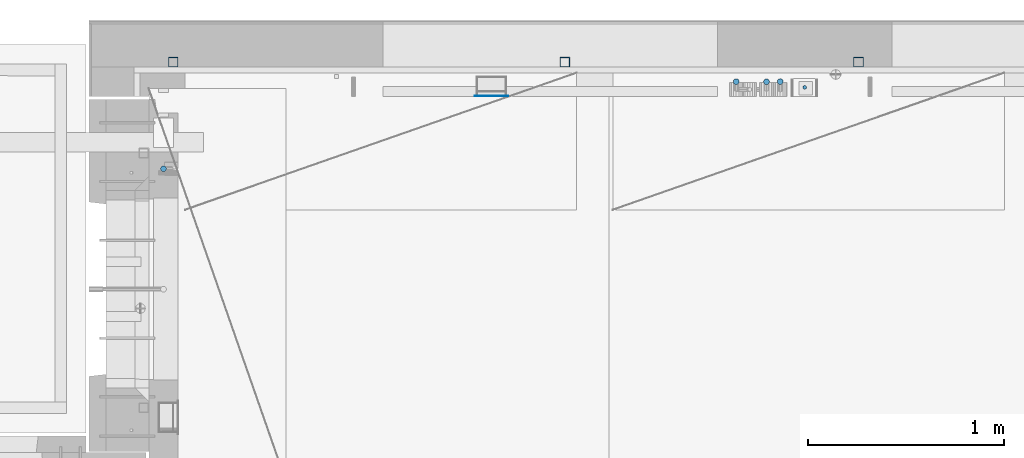
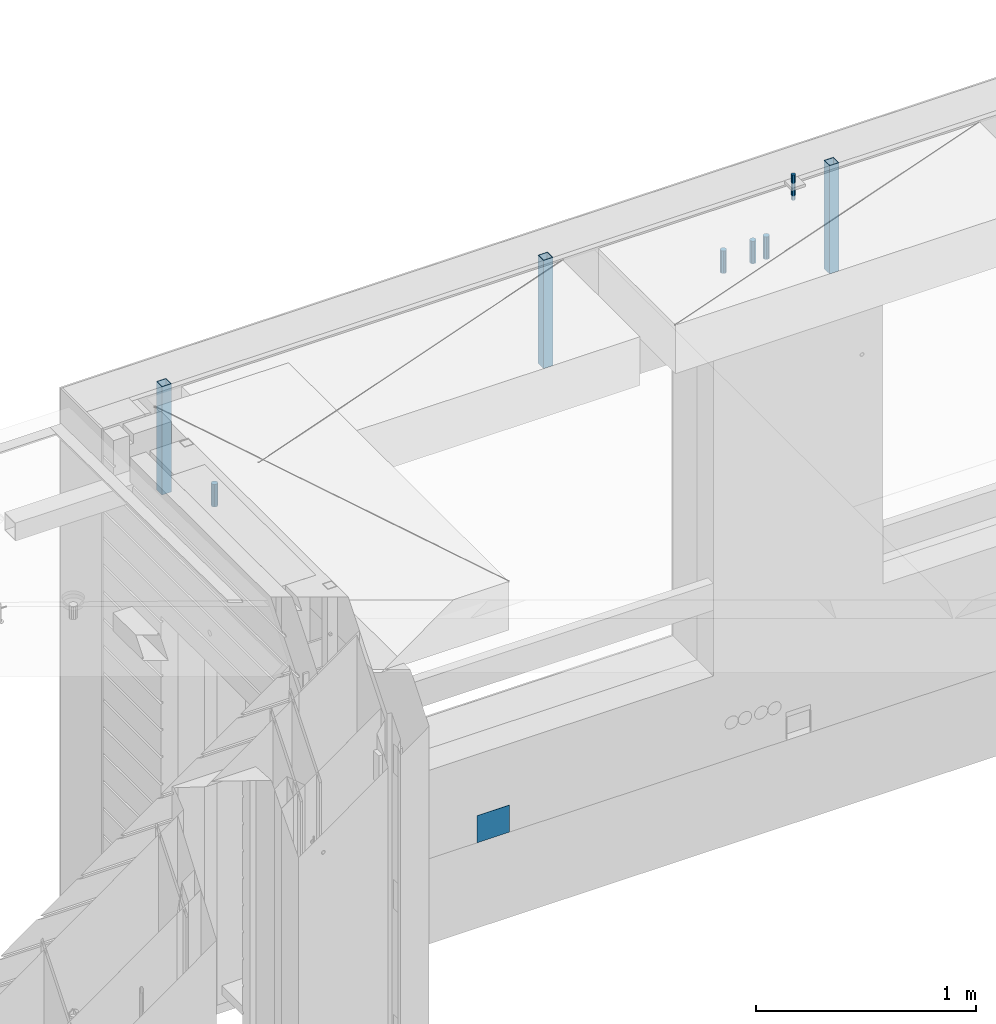
# One storey, part 29 of 350: 9 columns, 7 elements without a shape of their own.
"""IFC2X3 building model written with IfcOpenShell, lengths in millimetres."""

from ifc_helpers import new_model, si_unit, frame, origin_with_axes, place, context, subcontext, project, spatial, faceted_brep, material, type_object, element, aggregate, save


model = new_model("IFC2X3")

# Units and contexts
model_context = context("Model", 3, precision=1e-05, world=origin_with_axes())
body_context = subcontext(model_context, "Body", "Model", "MODEL_VIEW")
ifc_project = project(units=[si_unit("LENGTHUNIT", "METRE", prefix="MILLI"), si_unit("AREAUNIT", "SQUARE_METRE"), si_unit("VOLUMEUNIT", "CUBIC_METRE"), si_unit("MASSUNIT", "GRAM", prefix="KILO"), si_unit("TIMEUNIT", "SECOND"), si_unit("PLANEANGLEUNIT", "RADIAN"), si_unit("SOLIDANGLEUNIT", "STERADIAN"), si_unit("THERMODYNAMICTEMPERATUREUNIT", "DEGREE_CELSIUS"), si_unit("LUMINOUSINTENSITYUNIT", "LUMEN")], contexts=[model_context])

# Site, building, storey
site_placement = place(None, origin_with_axes())
site = spatial("IfcSite", under=ifc_project, at=site_placement, CompositionType="ELEMENT")
building_placement = place(site_placement, origin_with_axes())
building = spatial("IfcBuilding", under=site, at=building_placement, CompositionType="ELEMENT")
storey_placement = place(building_placement, origin_with_axes())
storey = spatial("IfcBuildingStorey", under=building, at=storey_placement, Name="2", CompositionType="ELEMENT", Elevation=0.0)

# Assembly, columns
assembly_1_placement = place(storey_placement, origin_with_axes())
assembly_1 = element("IfcElementAssembly", 1, at=assembly_1_placement, inside=storey, AssemblyPlace="NOTDEFINED", PredefinedType="REINFORCEMENT_UNIT")
ifc_material_1 = material()
column_type_1 = type_object("IfcColumnType", Name="D30", PredefinedType="NOTDEFINED")
column_1_placement = place(assembly_1_placement, frame((13990.0000000048, 22694.9999977209, 87407.5), z_axis=(0.0, 1.0, 0.0), x_axis=(0.0, 0.0, 1.0)))
column_1 = element("IfcColumn", 2, at=column_1_placement, type_object=column_type_1, material=ifc_material_1, ObjectType="D30", context=body_context, shape_type="Brep", body=[
    faceted_brep([(0.0, -15.0, 0.0), (0.0, -12.9903810567666, -7.5), (125.0, -12.9903810567666, -7.5), (125.0, -15.0, 0.0), (0.0, -7.5, -12.9903810567666), (125.0, -7.5, -12.9903810567666), (0.0, 0.0, -15.0), (125.0, 0.0, -15.0), (0.0, 7.5, -12.9903810567666), (125.0, 7.5, -12.9903810567666), (0.0, 12.9903810567666, -7.5), (125.0, 12.9903810567666, -7.5), (0.0, 15.0, 0.0), (125.0, 15.0, 0.0), (0.0, 12.9903810567666, 7.5), (125.0, 12.9903810567666, 7.5), (0.0, 7.5, 12.9903810567666), (125.0, 7.5, 12.9903810567666), (0.0, 0.0, 15.0), (125.0, 0.0, 15.0), (0.0, -7.5, 12.9903810567666), (125.0, -7.5, 12.9903810567666), (0.0, -12.9903810567666, 7.5), (125.0, -12.9903810567666, 7.5)], [[[0, 1, 2, 3]], [[1, 4, 5, 2]], [[4, 6, 7, 5]], [[6, 8, 9, 7]], [[8, 10, 11, 9]], [[10, 12, 13, 11]], [[12, 14, 15, 13]], [[14, 16, 17, 15]], [[16, 18, 19, 17]], [[18, 20, 21, 19]], [[20, 22, 23, 21]], [[22, 0, 3, 23]], [[5, 7, 9, 11, 13, 15, 17, 19, 21, 23, 3, 2]], [[22, 20, 18, 16, 14, 12, 10, 8, 6, 4, 1, 0]]]),
])
column_2_placement = place(assembly_1_placement, frame((14145.0000000048, 22694.9999977209, 87407.5), z_axis=(0.0, 1.0, 0.0), x_axis=(0.0, 0.0, 1.0)))
column_2 = element("IfcColumn", 3, at=column_2_placement, type_object=column_type_1, material=ifc_material_1, ObjectType="D30", context=body_context, shape_type="Brep", body=[
    faceted_brep([(0.0, -15.0, 0.0), (0.0, -12.9903810567666, -7.5), (125.0, -12.9903810567666, -7.5), (125.0, -15.0, 0.0), (0.0, -7.5, -12.9903810567666), (125.0, -7.5, -12.9903810567666), (0.0, 0.0, -15.0), (125.0, 0.0, -15.0), (0.0, 7.5, -12.9903810567666), (125.0, 7.5, -12.9903810567666), (0.0, 12.9903810567666, -7.5), (125.0, 12.9903810567666, -7.5), (0.0, 15.0, 0.0), (125.0, 15.0, 0.0), (0.0, 12.9903810567666, 7.5), (125.0, 12.9903810567666, 7.5), (0.0, 7.5, 12.9903810567666), (125.0, 7.5, 12.9903810567666), (0.0, 0.0, 15.0), (125.0, 0.0, 15.0), (0.0, -7.5, 12.9903810567666), (125.0, -7.5, 12.9903810567666), (0.0, -12.9903810567666, 7.5), (125.0, -12.9903810567666, 7.5)], [[[0, 1, 2, 3]], [[1, 4, 5, 2]], [[4, 6, 7, 5]], [[6, 8, 9, 7]], [[8, 10, 11, 9]], [[10, 12, 13, 11]], [[12, 14, 15, 13]], [[14, 16, 17, 15]], [[16, 18, 19, 17]], [[18, 20, 21, 19]], [[20, 22, 23, 21]], [[22, 0, 3, 23]], [[5, 7, 9, 11, 13, 15, 17, 19, 21, 23, 3, 2]], [[22, 20, 18, 16, 14, 12, 10, 8, 6, 4, 1, 0]]]),
])
column_3_placement = place(assembly_1_placement, frame((14215.0000000048, 22694.9999977209, 87407.5), z_axis=(0.0, 1.0, 0.0), x_axis=(0.0, 0.0, 1.0)))
column_3 = element("IfcColumn", 4, at=column_3_placement, type_object=column_type_1, material=ifc_material_1, ObjectType="D30", context=body_context, shape_type="Brep", body=[
    faceted_brep([(0.0, -15.0, 0.0), (0.0, -12.9903810567666, -7.5), (125.0, -12.9903810567666, -7.5), (125.0, -15.0, 0.0), (0.0, -7.5, -12.9903810567666), (125.0, -7.5, -12.9903810567666), (0.0, 0.0, -15.0), (125.0, 0.0, -15.0), (0.0, 7.5, -12.9903810567666), (125.0, 7.5, -12.9903810567666), (0.0, 12.9903810567666, -7.5), (125.0, 12.9903810567666, -7.5), (0.0, 15.0, 0.0), (125.0, 15.0, 0.0), (0.0, 12.9903810567666, 7.5), (125.0, 12.9903810567666, 7.5), (0.0, 7.5, 12.9903810567666), (125.0, 7.5, 12.9903810567666), (0.0, 0.0, 15.0), (125.0, 0.0, 15.0), (0.0, -7.5, 12.9903810567666), (125.0, -7.5, 12.9903810567666), (0.0, -12.9903810567666, 7.5), (125.0, -12.9903810567666, 7.5)], [[[0, 1, 2, 3]], [[1, 4, 5, 2]], [[4, 6, 7, 5]], [[6, 8, 9, 7]], [[8, 10, 11, 9]], [[10, 12, 13, 11]], [[12, 14, 15, 13]], [[14, 16, 17, 15]], [[16, 18, 19, 17]], [[18, 20, 21, 19]], [[20, 22, 23, 21]], [[22, 0, 3, 23]], [[5, 7, 9, 11, 13, 15, 17, 19, 21, 23, 3, 2]], [[22, 20, 18, 16, 14, 12, 10, 8, 6, 4, 1, 0]]]),
])

# Assembly, column
assembly_2_placement = place(storey_placement, origin_with_axes())
assembly_2 = element("IfcElementAssembly", 5, at=assembly_2_placement, inside=storey, AssemblyPlace="NOTDEFINED", PredefinedType="REINFORCEMENT_UNIT")
column_4_placement = place(assembly_2_placement, frame((11065.0, 22249.9963332647, 87407.5), z_axis=(-1.0, 3.00000001838171e-08, 0.0), x_axis=(0.0, 0.0, 1.0)))
column_4 = element("IfcColumn", 6, at=column_4_placement, type_object=column_type_1, material=ifc_material_1, ObjectType="D30", context=body_context, shape_type="Brep", body=[
    faceted_brep([(0.0, -15.0, 0.0), (0.0, -12.9903810567666, -7.5), (125.0, -12.9903810567666, -7.5), (125.0, -15.0, 0.0), (0.0, -7.5, -12.9903810567666), (125.0, -7.5, -12.9903810567666), (0.0, 0.0, -15.0), (125.0, 0.0, -15.0), (0.0, 7.5, -12.9903810567666), (125.0, 7.5, -12.9903810567666), (0.0, 12.9903810567666, -7.5), (125.0, 12.9903810567666, -7.5), (0.0, 15.0, 0.0), (125.0, 15.0, 0.0), (0.0, 12.9903810567666, 7.5), (125.0, 12.9903810567666, 7.5), (0.0, 7.5, 12.9903810567666), (125.0, 7.5, 12.9903810567666), (0.0, 0.0, 15.0), (125.0, 0.0, 15.0), (0.0, -7.5, 12.9903810567666), (125.0, -7.5, 12.9903810567666), (0.0, -12.9903810567666, 7.5), (125.0, -12.9903810567666, 7.5)], [[[0, 1, 2, 3]], [[1, 4, 5, 2]], [[4, 6, 7, 5]], [[6, 8, 9, 7]], [[8, 10, 11, 9]], [[10, 12, 13, 11]], [[12, 14, 15, 13]], [[14, 16, 17, 15]], [[16, 18, 19, 17]], [[18, 20, 21, 19]], [[20, 22, 23, 21]], [[22, 0, 3, 23]], [[5, 7, 9, 11, 13, 15, 17, 19, 21, 23, 3, 2]], [[22, 20, 18, 16, 14, 12, 10, 8, 6, 4, 1, 0]]]),
])
aggregate(assembly_2, [column_4])

assembly_3_placement = place(assembly_1_placement, origin_with_axes())
assembly_3 = element("IfcElementAssembly", 7, at=assembly_3_placement, Name="Steel Assembly", AssemblyPlace="NOTDEFINED", PredefinedType="NOTDEFINED")
ifc_material_2 = material(Name="Undefined")
column_type_2 = type_object("IfcColumnType", PredefinedType="NOTDEFINED")
column_5_placement = place(assembly_3_placement, frame((12740.0, 22620.9999977216, 84755.0000000024), z_axis=(0.0, -1.0, 0.0), x_axis=(0.0, 0.0, 1.0)))
column_5 = element("IfcColumn", 8, at=column_5_placement, type_object=column_type_2, material=ifc_material_2, Name="SPK2", context=body_context, shape_type="Brep", body=[
    faceted_brep([(0.0, 85.0, -1.0), (0.0, 85.0, 1.0), (150.0, 85.0, 1.0), (150.0, 85.0, -1.0), (0.0, -85.0, 1.0), (150.0, -85.0, 1.0), (0.0, -85.0, -1.0), (150.0, -85.0, -1.0)], [[[0, 1, 2, 3]], [[1, 4, 5, 2]], [[4, 6, 7, 5]], [[6, 0, 3, 7]], [[5, 7, 3, 2]], [[6, 4, 1, 0]]]),
])
aggregate(assembly_3, [column_5])

assembly_4_placement = place(assembly_1_placement, origin_with_axes())
assembly_4 = element("IfcElementAssembly", 9, at=assembly_4_placement, Name="Steel Assembly", AssemblyPlace="NOTDEFINED", PredefinedType="RIGID_FRAME")
ifc_material_3 = material(Name="STEEL/S355J2")
column_type_3 = type_object("IfcColumnType", Name="50X50X3", PredefinedType="NOTDEFINED")
column_6_placement = place(assembly_4_placement, frame((14615.0, 22795.0, 87140.0), z_axis=(1.0, 0.0, 0.0), x_axis=(0.0, 0.0, 1.0)))
column_6 = element("IfcColumn", 10, at=column_6_placement, type_object=column_type_3, material=ifc_material_3, ObjectType="50X50X3", context=body_context, shape_type="Brep", body=[
    faceted_brep([(0.0, 22.0, -22.0), (0.0, -22.0, -22.0), (600.0, -22.0, -22.0), (600.0, 22.0, -22.0), (0.0, -22.0, 22.0), (600.0, -22.0, 22.0), (0.0, 22.0, 22.0), (600.0, 22.0, 22.0), (0.0, 25.0, -25.0), (0.0, 25.0, 25.0), (600.0, 25.0, 25.0), (600.0, 25.0, -25.0), (0.0, -25.0, 25.0), (600.0, -25.0, 25.0), (0.0, -25.0, -25.0), (600.0, -25.0, -25.0)], [[[0, 1, 2, 3]], [[1, 4, 5, 2]], [[4, 6, 7, 5]], [[6, 0, 3, 7]], [[8, 9, 10, 11]], [[9, 12, 13, 10]], [[12, 14, 15, 13]], [[14, 8, 11, 15]], [[13, 15, 11, 10], [5, 7, 3, 2]], [[14, 12, 9, 8], [6, 4, 1, 0]]]),
])
aggregate(assembly_4, [column_6])

assembly_5_placement = place(assembly_1_placement, origin_with_axes())
assembly_5 = element("IfcElementAssembly", 11, at=assembly_5_placement, Name="Steel Assembly", AssemblyPlace="NOTDEFINED", PredefinedType="RIGID_FRAME")
column_7_placement = place(assembly_5_placement, frame((13115.0, 22795.0, 87140.0), z_axis=(1.0, 0.0, 0.0), x_axis=(0.0, 0.0, 1.0)))
column_7 = element("IfcColumn", 12, at=column_7_placement, type_object=column_type_3, material=ifc_material_3, ObjectType="50X50X3", context=body_context, shape_type="Brep", body=[
    faceted_brep([(0.0, 22.0, -22.0), (0.0, -22.0, -22.0), (600.0, -22.0, -22.0), (600.0, 22.0, -22.0), (0.0, -22.0, 22.0), (600.0, -22.0, 22.0), (0.0, 22.0, 22.0), (600.0, 22.0, 22.0), (0.0, 25.0, -25.0), (0.0, 25.0, 25.0), (600.0, 25.0, 25.0), (600.0, 25.0, -25.0), (0.0, -25.0, 25.0), (600.0, -25.0, 25.0), (0.0, -25.0, -25.0), (600.0, -25.0, -25.0)], [[[0, 1, 2, 3]], [[1, 4, 5, 2]], [[4, 6, 7, 5]], [[6, 0, 3, 7]], [[8, 9, 10, 11]], [[9, 12, 13, 10]], [[12, 14, 15, 13]], [[14, 8, 11, 15]], [[13, 15, 11, 10], [5, 7, 3, 2]], [[14, 12, 9, 8], [6, 4, 1, 0]]]),
])
aggregate(assembly_5, [column_7])

assembly_6_placement = place(assembly_1_placement, origin_with_axes())
assembly_6 = element("IfcElementAssembly", 13, at=assembly_6_placement, Name="Steel Assembly", AssemblyPlace="NOTDEFINED", PredefinedType="RIGID_FRAME")
column_8_placement = place(assembly_6_placement, frame((11115.0, 22795.0, 87140.0), z_axis=(1.0, 0.0, 0.0), x_axis=(0.0, 0.0, 1.0)))
column_8 = element("IfcColumn", 14, at=column_8_placement, type_object=column_type_3, material=ifc_material_3, ObjectType="50X50X3", context=body_context, shape_type="Brep", body=[
    faceted_brep([(0.0, 22.0, -22.0), (0.0, -22.0, -22.0), (600.0, -22.0, -22.0), (600.0, 22.0, -22.0), (0.0, -22.0, 22.0), (600.0, -22.0, 22.0), (0.0, 22.0, 22.0), (600.0, 22.0, 22.0), (0.0, 25.0, -25.0), (0.0, 25.0, 25.0), (600.0, 25.0, 25.0), (600.0, 25.0, -25.0), (0.0, -25.0, 25.0), (600.0, -25.0, 25.0), (0.0, -25.0, -25.0), (600.0, -25.0, -25.0)], [[[0, 1, 2, 3]], [[1, 4, 5, 2]], [[4, 6, 7, 5]], [[6, 0, 3, 7]], [[8, 9, 10, 11]], [[9, 12, 13, 10]], [[12, 14, 15, 13]], [[14, 8, 11, 15]], [[13, 15, 11, 10], [5, 7, 3, 2]], [[14, 12, 9, 8], [6, 4, 1, 0]]]),
])
aggregate(assembly_6, [column_8])

# Assembly
assembly_7_placement = place(assembly_1_placement, origin_with_axes())
assembly_7 = element("IfcElementAssembly", 15, at=assembly_7_placement, Name="Steel Assembly", AssemblyPlace="NOTDEFINED", PredefinedType="RIGID_FRAME")

aggregate(assembly_1, [column_1, column_2, column_3, assembly_7, assembly_4, assembly_3, assembly_5, assembly_6])

# Column
ifc_material_4 = material(Name="STEEL/Steel_Undefined")
column_type_4 = type_object("IfcColumnType", Name="D20", PredefinedType="NOTDEFINED")
column_9_placement = place(assembly_7_placement, frame((14340.0, 22665.9999913613, 87705.0), z_axis=(0.0, 1.0, 0.0), x_axis=(0.0, 0.0, 1.0)))
column_9 = element("IfcColumn", 16, at=column_9_placement, type_object=column_type_4, material=ifc_material_4, ObjectType="D20", context=body_context, shape_type="Brep", body=[
    faceted_brep([(0.0, -10.0, 0.0), (-4.19531716033816e-08, -7.07106781186667, -7.07106781187031), (140.0, -7.07106781186485, -7.07106781186667), (140.0, -10.0, 0.0), (0.0, 0.0, -10.0), (140.0, 0.0, -10.0), (4.196772351861e-08, 7.07106781186303, -7.07106781186667), (140.0, 7.07106781186485, -7.07106781186667), (0.0, 10.0, 0.0), (140.0, 10.0, 0.0), (4.196772351861e-08, 7.07106781185939, 7.07106781185939), (140.0, 7.07106781186485, 7.07106781186667), (0.0, 0.0, 10.0), (140.0, 0.0, 10.0), (-4.19531716033816e-08, -7.07106781187031, 7.07106781185939), (140.0, -7.07106781186485, 7.07106781186667)], [[[0, 1, 2, 3]], [[1, 4, 5, 2]], [[4, 6, 7, 5]], [[6, 8, 9, 7]], [[8, 10, 11, 9]], [[10, 12, 13, 11]], [[12, 14, 15, 13]], [[14, 0, 3, 15]], [[5, 7, 9, 11, 13, 15, 3, 2]], [[14, 12, 10, 8, 6, 4, 1, 0]]]),
])

aggregate(assembly_7, [column_9])

save(model, "model.ifc")
